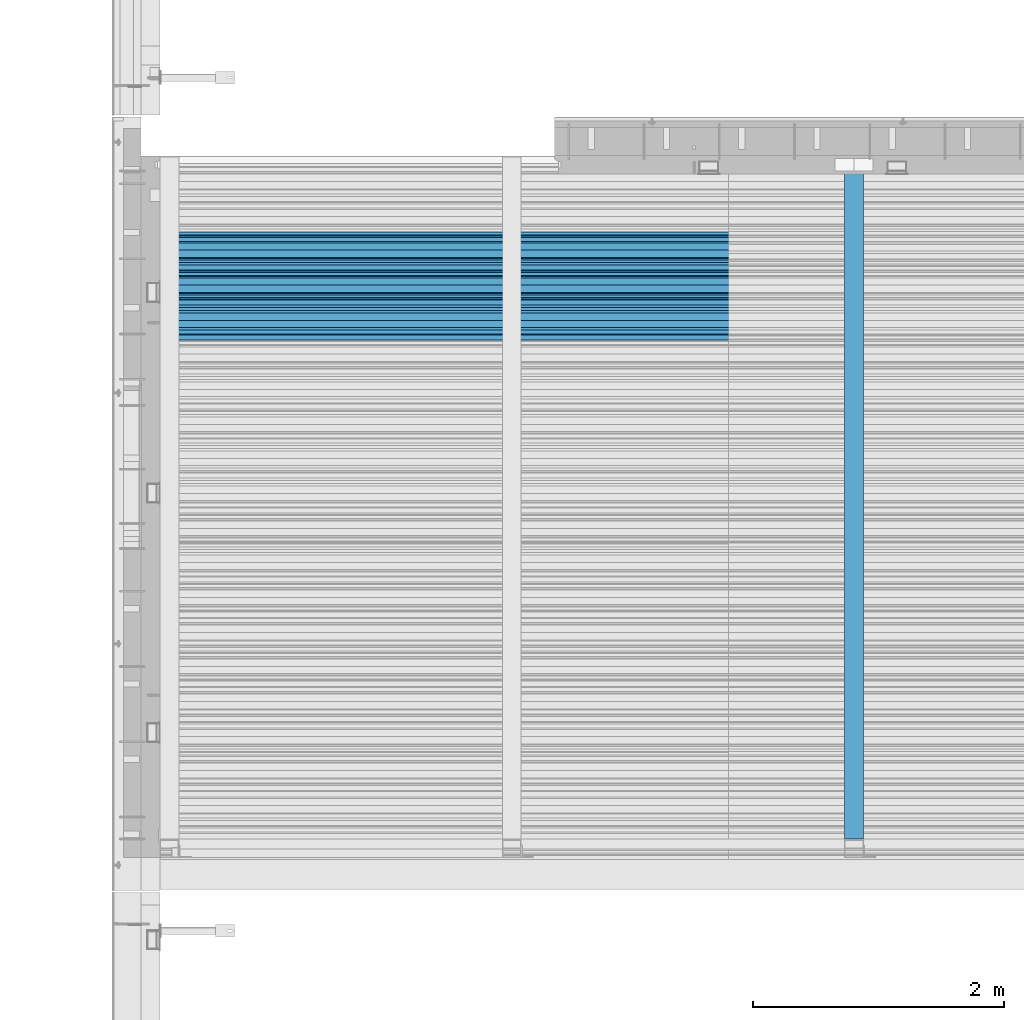
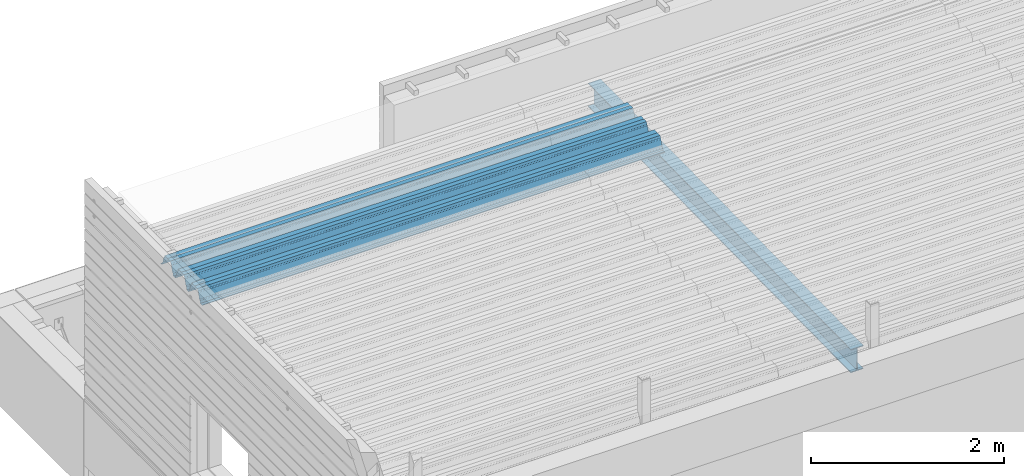
# One storey, part 29 of 153: 2 beams, 2 elements without a shape of their own.
"""IFC2X3 building model written with IfcOpenShell, lengths in millimetres."""

from ifc_helpers import new_model, si_unit, frame, origin_with_axes, place, context, subcontext, project, spatial, faceted_brep, material, type_object, element, aggregate, save


model = new_model("IFC2X3")

# Units and contexts
model_context = context("Model", 3, precision=1e-05, world=origin_with_axes())
body_context = subcontext(model_context, "Body", "Model", "MODEL_VIEW")
ifc_project = project(units=[si_unit("LENGTHUNIT", "METRE", prefix="MILLI"), si_unit("AREAUNIT", "SQUARE_METRE"), si_unit("VOLUMEUNIT", "CUBIC_METRE"), si_unit("MASSUNIT", "GRAM", prefix="KILO"), si_unit("TIMEUNIT", "SECOND"), si_unit("PLANEANGLEUNIT", "RADIAN"), si_unit("SOLIDANGLEUNIT", "STERADIAN"), si_unit("THERMODYNAMICTEMPERATUREUNIT", "DEGREE_CELSIUS"), si_unit("LUMINOUSINTENSITYUNIT", "LUMEN")], contexts=[model_context])

# Site, building, storey
site_placement = place(None, origin_with_axes())
site = spatial("IfcSite", under=ifc_project, at=site_placement, CompositionType="ELEMENT")
building_placement = place(site_placement, origin_with_axes())
building = spatial("IfcBuilding", under=site, at=building_placement, CompositionType="ELEMENT")
storey_placement = place(building_placement, origin_with_axes())
storey = spatial("IfcBuildingStorey", under=building, at=storey_placement, Name="8", CompositionType="ELEMENT", Elevation=0.0)

# Assembly, beam
assembly_1_placement = place(storey_placement, origin_with_axes())
assembly_1 = element("IfcElementAssembly", 1, at=assembly_1_placement, inside=storey, Name="Steel Assembly", AssemblyPlace="NOTDEFINED", PredefinedType="RIGID_FRAME")
ifc_material = material(Name="STEEL/S355J2")
beam_type_1 = type_object("IfcBeamType", Name="IPE300", PredefinedType="NOTDEFINED")
beam_1_placement = place(assembly_1_placement, frame((13535.0, 15128.0908589797, 105518.668698055), z_axis=(0.0, -0.0124990270013869, 0.999921884110963), x_axis=(0.0, 0.999921884110963, 0.0124990270013883)))
beam_1 = element("IfcBeam", 2, at=beam_1_placement, type_object=beam_type_1, material=ifc_material, ObjectType="IPE300", context=body_context, shape_type="Brep", body=[
    faceted_brep([(3.63797880709171e-12, 75.0, -149.999999999985), (0.0, 75.0, -139.300000189993), (5440.87494889885, 75.0, -139.300000189993), (5440.87494889886, 75.0, -150.0), (0.0, 3.5499999525, -139.300000189993), (5440.87494889885, 3.5499999525, -139.300000189993), (0.0, 3.5499999525, 139.300000190022), (5440.87494889885, 3.5499999525, 139.300000190022), (0.0, 75.0, 139.300000190022), (5440.87494889885, 75.0, 139.300000190022), (3.63797880709171e-12, 75.0, 150.0), (5440.87494889885, 75.0, 150.0), (3.63797880709171e-12, -75.0, 150.0), (5440.87494889885, -75.0, 150.0), (0.0, -75.0, 139.300000190022), (5440.87494889885, -75.0, 139.300000190022), (0.0, -3.5499999525, 139.300000190022), (5440.87494889885, -3.5499999525, 139.300000190022), (0.0, -3.5499999525, -139.300000189993), (5440.87494889885, -3.5499999525, -139.300000189993), (0.0, -75.0, -139.300000189993), (5440.87494889885, -75.0, -139.300000189993), (3.63797880709171e-12, -75.0, -149.999999999985), (5440.87494889886, -75.0, -150.0)], [[[0, 1, 2, 3]], [[1, 4, 5, 2]], [[4, 6, 7, 5]], [[6, 8, 9, 7]], [[8, 10, 11, 9]], [[10, 12, 13, 11]], [[12, 14, 15, 13]], [[14, 16, 17, 15]], [[16, 18, 19, 17]], [[18, 20, 21, 19]], [[20, 22, 23, 21]], [[22, 0, 3, 23]], [[5, 7, 9, 11, 13, 15, 17, 19, 21, 23, 3, 2]], [[22, 20, 18, 16, 14, 12, 10, 8, 6, 4, 1, 0]]]),
])
aggregate(assembly_1, [beam_1])

assembly_2_placement = place(storey_placement, origin_with_axes())
assembly_2 = element("IfcElementAssembly", 3, at=assembly_2_placement, inside=storey, Name="Steel Assembly", AssemblyPlace="NOTDEFINED", PredefinedType="RIGID_FRAME")
beam_type_2 = type_object("IfcBeamType", Name="W", PredefinedType="NOTDEFINED")
beam_2_placement = place(assembly_2_placement, frame((13534.9999999929, 19534.8848732893, 105801.771450403), z_axis=(0.0, -0.0124990270013869, 0.999921884110963), x_axis=(-1.0, 3.00000001838171e-08, 0.0)))
beam_2 = element("IfcBeam", 4, at=beam_2_placement, type_object=beam_type_2, material=ifc_material, ObjectType="W", context=body_context, shape_type="Brep", body=[
    faceted_brep([(0.0, -412.839996337891, -77.0100021362159), (0.0, -409.160003662109, -77.0100021362014), (5530.0, -409.160003662109, -77.0100021362014), (5530.0, -412.839996337891, -77.0100021362159), (0.0, -408.070007324222, -73.4800033569045), (5530.0, -408.070007324222, -73.4800033569045), (0.0, -400.339996337894, -48.0600013732619), (5530.0, -400.339996337894, -48.0600013732619), (0.0, -399.459991455082, -46.5600013732619), (5530.0, -399.459991455082, -46.5600013732619), (0.0, -390.329986572269, -36.5499992370314), (5530.0, -390.329986572269, -36.5499992370314), (0.0, -389.19000244141, -34.6300010680861), (5530.0, -389.19000244141, -34.6300010680861), (0.0, -367.820007324222, 35.3400001526024), (5530.0, -367.820007324222, 35.3400001526024), (0.0, -366.989990234379, 36.8499984741502), (5530.0, -366.989990234379, 36.8499984741502), (0.0, -357.809997558597, 46.8600006103807), (5530.0, -357.809997558597, 46.8600006103807), (0.0, -356.720001220707, 48.7700004577782), (5530.0, -356.720001220707, 48.7700004577782), (0.0, -349.309997558594, 73.1500015258935), (5530.0, -349.309997558594, 73.1500015258935), (0.0, -347.850006103516, 75.2300033569481), (5530.0, -347.850006103516, 75.2300033569481), (0.0, -345.470001220707, 76.010002136245), (5530.0, -345.470001220707, 76.010002136245), (0.0, -305.480010986332, 76.010002136245), (5530.0, -305.480010986332, 76.010002136245), (0.0, -304.279998779301, 75.8000030517578), (5530.0, -304.279998779301, 75.8000030517578), (0.0, -291.679992675785, 71.6999969482567), (5530.0, -291.679992675785, 71.6999969482567), (0.0, -290.179992675789, 71.2300033569481), (5530.0, -290.179992675789, 71.2300033569481), (0.0, -288.720001220707, 71.6999969482567), (5530.0, -288.720001220707, 71.6999969482567), (0.0, -276.119995117191, 75.8000030517869), (5530.0, -276.119995117191, 75.8000030517869), (0.0, -274.929992675785, 76.010002136245), (5530.0, -274.929992675785, 76.010002136245), (0.0, -234.94000244141, 76.010002136245), (5530.0, -234.94000244141, 76.010002136245), (0.0, -232.550003051758, 75.2300033569627), (5530.0, -232.550003051758, 75.2300033569627), (0.0, -231.100006103519, 73.1500015258935), (5530.0, -231.100006103519, 73.1500015258935), (0.0, -223.679992675785, 48.7700004577782), (5530.0, -223.679992675785, 48.7700004577782), (0.0, -222.589996337894, 46.8600006103661), (5530.0, -222.589996337894, 46.8600006103661), (0.0, -213.410003662113, 36.8499984741502), (5530.0, -213.410003662113, 36.8499984741502), (0.0, -212.529998779301, 35.3400001526024), (5530.0, -212.529998779301, 35.3400001526024), (0.0, -191.160003662109, -34.6300010681007), (5530.0, -191.160003662109, -34.6300010681007), (0.0, -190.070007324222, -36.5499992370605), (5530.0, -190.070007324222, -36.5499992370605), (0.0, -180.940002441406, -46.560001373291), (5530.0, -180.940002441406, -46.560001373291), (0.0, -180.059997558597, -48.0600013732619), (5530.0, -180.059997558597, -48.0600013732619), (0.0, -172.330001831055, -73.480003356919), (5530.0, -172.330001831055, -73.480003356919), (0.0, -171.240005493168, -77.0100021362159), (5530.0, -171.240005493168, -77.0100021362159), (0.0, -129.330001831062, -77.0100021362014), (5530.0, -129.330001831062, -77.0100021362014), (0.0, -128.300003051761, -73.480003356919), (5530.0, -128.300003051761, -73.480003356919), (0.0, -120.51999664307, -48.0600013732765), (5530.0, -120.51999664307, -48.0600013732765), (0.0, -119.629997253418, -46.5600013732765), (5530.0, -119.629997253418, -46.5600013732765), (0.0, -110.500000000004, -36.5499992370314), (5530.0, -110.500000000004, -36.5499992370314), (0.0, -109.419998168949, -34.6300010680861), (5530.0, -109.419998168949, -34.6300010680861), (0.0, -88.0500030517615, 35.3400001526024), (5530.0, -88.0500030517615, 35.3400001526024), (0.0, -87.160003662113, 36.8499984741356), (5530.0, -87.160003662113, 36.8499984741356), (0.0, -78.0400009155273, 46.8600006103807), (5530.0, -78.0400009155273, 46.8600006103807), (0.0, -76.8899993896557, 48.7700004577782), (5530.0, -76.8899993896557, 48.7700004577782), (0.0, -69.4800033569336, 73.1500015258935), (5530.0, -69.4800033569336, 73.1500015258935), (0.0, -68.0299987793042, 75.2300033569336), (5530.0, -68.0299987793042, 75.2300033569336), (0.0, -65.6399993896521, 76.010002136245), (5530.0, -65.6399993896521, 76.010002136245), (0.0, -25.6499996185375, 76.0100021362596), (5530.0, -25.6499996185375, 76.0100021362596), (0.0, -24.5100002288891, 75.8000030517724), (5530.0, -24.5100002288891, 75.8000030517724), (0.0, -11.8500003814697, 71.6999969482567), (5530.0, -11.8500003814697, 71.6999969482567), (0.0, -10.3999996185339, 71.2300033569481), (5530.0, -10.3999996185339, 71.2300033569481), (0.0, -8.89999961853391, 71.6999969482567), (5530.0, -8.89999961853391, 71.6999969482567), (0.0, 3.71000003814333, 75.8000030517724), (5530.0, 3.71000003814333, 75.8000030517724), (0.0, 4.90000009536379, 76.0100021362596), (5530.0, 4.90000009536379, 76.0100021362596), (0.0, 44.8899993896484, 76.010002136245), (5530.0, 44.8899993896484, 76.010002136245), (0.0, 47.2799987792932, 75.2300033569481), (5530.0, 47.2799987792932, 75.2300033569481), (0.0, 48.6800003051721, 73.1500015258935), (5530.0, 48.6800003051721, 73.1500015258935), (0.0, 56.1500015258753, 48.7700004577782), (5530.0, 56.1500015258753, 48.7700004577782), (0.0, 57.2400016784632, 46.8600006103807), (5530.0, 57.2400016784632, 46.8600006103807), (0.0, 66.3700027465784, 36.8499984741211), (5530.0, 66.3700027465784, 36.8499984741211), (0.0, 67.2499999999964, 35.3400001526024), (5530.0, 67.2499999999964, 35.3400001526024), (0.0, 88.6200027465748, -34.6300010681007), (5530.0, 88.6200027465748, -34.6300010681007), (0.0, 89.709999084469, -36.549999237046), (5530.0, 89.709999084469, -36.549999237046), (0.0, 98.8899993896412, -46.5600013732765), (5530.0, 98.8899993896412, -46.5600013732765), (0.0, 99.7699966430628, -48.0600013732765), (5530.0, 99.7699966430628, -48.0600013732765), (0.0, 107.499999999996, -73.4800033569336), (5530.0, 107.499999999996, -73.4800033569336), (0.0, 108.589996337887, -77.0100021362014), (5530.0, 108.589996337887, -77.0100021362014), (0.0, 112.269996643063, -77.0100021362159), (5530.0, 112.269996643063, -77.0100021362159), (0.0, 146.759994506836, -77.0100021362159), (5530.0, 146.759994506836, -77.0100021362159), (0.0, 150.440002441403, -77.0100021362159), (5530.0, 150.440002441403, -77.0100021362159), (0.0, 151.529998779297, -73.480003356919), (5530.0, 151.529998779297, -73.480003356919), (0.0, 159.30999755859, -48.0600013732765), (5530.0, 159.30999755859, -48.0600013732765), (0.0, 160.190002441406, -46.5600013732619), (5530.0, 160.190002441406, -46.5600013732619), (0.0, 169.320007324215, -36.549999237046), (5530.0, 169.320007324215, -36.549999237046), (0.0, 170.410003662106, -34.6300010680861), (5530.0, 170.410003662106, -34.6300010680861), (0.0, 191.779998779293, 35.3400001526024), (5530.0, 191.779998779293, 35.3400001526024), (0.0, 192.660003662109, 36.8499984741502), (5530.0, 192.660003662109, 36.8499984741502), (0.0, 201.789993286129, 46.8600006103661), (5530.0, 201.789993286129, 46.8600006103661), (0.0, 202.880004882809, 48.7700004577637), (5530.0, 202.880004882809, 48.7700004577637), (0.0, 210.350006103512, 73.150001525908), (5530.0, 210.350006103512, 73.150001525908), (0.0, 211.800003051754, 75.2300033569481), (5530.0, 211.800003051754, 75.2300033569481), (0.0, 214.190002441406, 76.010002136245), (5530.0, 214.190002441406, 76.010002136245), (0.0, 254.179992675778, 76.010002136245), (5530.0, 254.179992675778, 76.010002136245), (0.0, 255.320007324215, 75.8000030517869), (5530.0, 255.320007324215, 75.8000030517869), (0.0, 267.980010986324, 71.6999969482713), (5530.0, 267.980010986324, 71.6999969482713), (0.0, 269.429992675778, 71.2300033569481), (5530.0, 269.429992675778, 71.2300033569481), (0.0, 270.880004882809, 71.6999969482567), (5530.0, 270.880004882809, 71.6999969482567), (0.0, 283.540008544918, 75.8000030517869), (5530.0, 283.540008544918, 75.8000030517869), (0.0, 284.679992675778, 76.010002136245), (5530.0, 284.679992675778, 76.010002136245), (0.0, 324.670013427731, 76.010002136245), (5530.0, 324.670013427731, 76.010002136245), (0.0, 327.049987792969, 75.2300033569627), (5530.0, 327.049987792969, 75.2300033569627), (0.0, 328.510009765625, 73.1500015258789), (5530.0, 328.510009765625, 73.1500015258789), (0.0, 335.980010986324, 48.7700004577782), (5530.0, 335.980010986324, 48.7700004577782), (0.0, 337.05999755859, 46.8600006103661), (5530.0, 337.05999755859, 46.8600006103661), (0.0, 346.190002441399, 36.8499984741356), (5530.0, 346.190002441399, 36.8499984741356), (0.0, 347.079986572266, 35.3400001526024), (5530.0, 347.079986572266, 35.3400001526024), (0.0, 368.450012207028, -34.6300010680861), (5530.0, 368.450012207028, -34.6300010680861), (0.0, 369.529998779293, -36.5499992370314), (5530.0, 369.529998779293, -36.5499992370314), (0.0, 378.660003662106, -46.5600013732619), (5530.0, 378.660003662106, -46.5600013732619), (0.0, 379.540008544918, -48.0600013732619), (5530.0, 379.540008544918, -48.0600013732619), (0.0, 387.329986572262, -73.480003356919), (5530.0, 387.329986572262, -73.480003356919), (0.0, 388.410003662109, -77.0100021362159), (5530.0, 388.410003662109, -77.0100021362159), (0.0, 392.100006103512, -77.0100021362159), (5530.0, 392.100006103512, -77.0100021362159), (0.0, 426.589996337887, -77.0100021362159), (5530.0, 426.589996337887, -77.0100021362159), (0.0, 430.269989013668, -77.0100021362159), (5530.0, 430.269989013668, -77.0100021362159), (0.0, 431.359985351559, -73.4800033569045), (5530.0, 431.359985351559, -73.4800033569045), (0.0, 433.179992675778, -67.5699996948097), (5530.0, 433.179992675778, -67.5699996948097), (0.0, 432.220001220699, -67.2699966430373), (5530.0, 432.220001220699, -67.2699966430373), (0.0, 430.410003662106, -73.1800003051612), (5530.0, 430.410003662106, -73.1800003051612), (0.0, 429.529998779293, -76.0100021362159), (5530.0, 429.529998779293, -76.0100021362159), (0.0, 426.589996337891, -76.0100021362159), (5530.0, 426.589996337891, -76.0100021362159), (0.0, 392.100006103512, -76.0100021362159), (5530.0, 392.100006103512, -76.0100021362159), (0.0, 389.149993896481, -76.0100021362014), (5530.0, 389.149993896481, -76.0100021362014), (0.0, 388.279998779293, -73.1800003051467), (5530.0, 388.279998779293, -73.1800003051467), (0.0, 380.470001220699, -47.659999847383), (5530.0, 380.470001220699, -47.659999847383), (0.0, 379.470001220699, -45.9599990844436), (5530.0, 379.470001220699, -45.9599990844436), (0.0, 370.350006103512, -35.9599990844581), (5530.0, 370.350006103512, -35.9599990844581), (0.0, 369.369995117184, -34.2299995422218), (5530.0, 369.369995117184, -34.2299995422218), (0.0, 347.999999999996, 35.7500000000146), (5530.0, 347.999999999996, 35.7500000000146), (0.0, 346.999999999996, 37.4399986267235), (5530.0, 346.999999999996, 37.4399986267235), (0.0, 337.880004882809, 47.450000762954), (5530.0, 337.880004882809, 47.450000762954), (0.0, 336.899993896481, 49.1699981689453), (5530.0, 336.899993896481, 49.1699981689453), (0.0, 329.420013427731, 73.5999984741356), (5530.0, 329.420013427731, 73.5999984741356), (0.0, 327.679992675781, 76.0699996948533), (5530.0, 327.679992675781, 76.0699996948533), (0.0, 324.829986572262, 77.010002136245), (5530.0, 324.829986572262, 77.010002136245), (0.0, 284.589996337887, 77.010002136245), (5530.0, 284.589996337887, 77.010002136245), (0.0, 283.290008544922, 76.769996643081), (5530.0, 283.290008544922, 76.769996643081), (0.0, 270.570007324215, 72.6500015258935), (5530.0, 270.570007324215, 72.6500015258935), (0.0, 269.429992675781, 72.2799987793114), (5530.0, 269.429992675781, 72.2799987793114), (0.0, 268.279998779293, 72.650001525908), (5530.0, 268.279998779293, 72.650001525908), (0.0, 255.570007324219, 76.769996643081), (5530.0, 255.570007324219, 76.769996643081), (0.0, 254.270004272461, 77.0100021362596), (5530.0, 254.270004272461, 77.0100021362596), (0.0, 214.029998779293, 77.0100021362596), (5530.0, 214.029998779293, 77.0100021362596), (0.0, 211.179992675781, 76.0699996948388), (5530.0, 211.179992675781, 76.0699996948388), (0.0, 209.440002441403, 73.5999984741356), (5530.0, 209.440002441403, 73.5999984741356), (0.0, 201.960006713864, 49.1699981689599), (5530.0, 201.960006713864, 49.1699981689599), (0.0, 200.979995727532, 47.450000762954), (5530.0, 200.979995727532, 47.450000762954), (0.0, 191.850006103508, 37.4399986267235), (5530.0, 191.850006103508, 37.4399986267235), (0.0, 190.860000610352, 35.7500000000146), (5530.0, 190.860000610352, 35.7500000000146), (0.0, 169.49000549316, -34.2299995422218), (5530.0, 169.49000549316, -34.2299995422218), (0.0, 168.509994506832, -35.9599990844581), (5530.0, 168.509994506832, -35.9599990844581), (0.0, 159.380004882805, -45.9599990844436), (5530.0, 159.380004882805, -45.9599990844436), (0.0, 158.389999389645, -47.6599998473976), (5530.0, 158.389999389645, -47.6599998473976), (0.0, 150.580001831051, -73.1800003051612), (5530.0, 150.580001831051, -73.1800003051612), (0.0, 149.710006713864, -76.0100021362159), (5530.0, 149.710006713864, -76.0100021362159), (0.0, 146.759994506836, -76.0100021362159), (5530.0, 146.759994506836, -76.0100021362159), (0.0, 112.269996643063, -76.0100021362159), (5530.0, 112.269996643063, -76.0100021362159), (0.0, 109.319999694821, -76.0100021362159), (5530.0, 109.319999694821, -76.0100021362159), (0.0, 108.449996948239, -73.1900024413917), (5530.0, 108.449996948239, -73.1900024413917), (0.0, 100.690002441406, -47.659999847383), (5530.0, 100.690002441406, -47.659999847383), (0.0, 99.6999969482386, -45.9599990844581), (5530.0, 99.6999969482386, -45.9599990844581), (0.0, 90.5199966430664, -35.9599990844581), (5530.0, 90.5199966430664, -35.9599990844581), (0.0, 89.5400009155273, -34.2299995422218), (5530.0, 89.5400009155273, -34.2299995422218), (0.0, 68.1699981689417, 35.7500000000146), (5530.0, 68.1699981689417, 35.7500000000146), (0.0, 67.1699981689417, 37.4399986267235), (5530.0, 67.1699981689417, 37.4399986267235), (0.0, 58.0499992370569, 47.4500007629686), (5530.0, 58.0499992370569, 47.4500007629686), (0.0, 57.0699996948206, 49.1699981689599), (5530.0, 57.0699996948206, 49.1699981689599), (0.0, 49.5900001525843, 73.5899963379052), (5530.0, 49.5900001525843, 73.5899963379052), (0.0, 47.9099998474085, 76.0699996948388), (5530.0, 47.9099998474085, 76.0699996948388), (0.0, 45.0499992370569, 77.010002136245), (5530.0, 45.0499992370569, 77.010002136245), (0.0, 4.82000017165774, 77.010002136245), (5530.0, 4.82000017165774, 77.010002136245), (0.0, 3.47000002860659, 76.7699966430955), (5530.0, 3.47000002860659, 76.7699966430955), (0.0, -9.19999980926514, 72.6500015258935), (5530.0, -9.19999980926514, 72.6500015258935), (0.0, -10.3900003433264, 72.2799987792969), (5530.0, -10.3900003433264, 72.2799987792969), (0.0, -11.5399999618567, 72.6500015258935), (5530.0, -11.5399999618567, 72.6500015258935), (0.0, -24.2600002288855, 76.769996643081), (5530.0, -24.2600002288855, 76.769996643081), (0.0, -25.559999465946, 77.0100021362596), (5530.0, -25.559999465946, 77.0100021362596), (0.0, -65.8000030517615, 77.0100021362596), (5530.0, -65.8000030517615, 77.0100021362596), (0.0, -68.6500015258862, 76.0699996948533), (5530.0, -68.6500015258862, 76.0699996948533), (0.0, -70.3899993896521, 73.5999984741356), (5530.0, -70.3899993896521, 73.5999984741356), (0.0, -77.8199996948242, 49.1800003051903), (5530.0, -77.8199996948242, 49.1800003051903), (0.0, -78.8399963378943, 47.450000762954), (5530.0, -78.8399963378943, 47.450000762954), (0.0, -87.9700012207031, 37.4399986267235), (5530.0, -87.9700012207031, 37.4399986267235), (0.0, -88.9700012207068, 35.7500000000146), (5530.0, -88.9700012207068, 35.7500000000146), (0.0, -110.339996337894, -34.2299995422218), (5530.0, -110.339996337894, -34.2299995422218), (0.0, -111.319999694828, -35.9599990844581), (5530.0, -111.319999694828, -35.9599990844581), (0.0, -120.440002441406, -45.9599990844436), (5530.0, -120.440002441406, -45.9599990844436), (0.0, -121.44000244141, -47.6599998473976), (5530.0, -121.44000244141, -47.6599998473976), (0.0, -129.250000000004, -73.1900024413771), (5530.0, -129.250000000004, -73.1900024413771), (0.0, -130.080001831062, -76.0100021362159), (5530.0, -130.080001831062, -76.0100021362159), (0.0, -170.5, -76.0100021362014), (5530.0, -170.5, -76.0100021362014), (0.0, -171.380004882816, -73.1900024413917), (5530.0, -171.380004882816, -73.1900024413917), (0.0, -179.139999389652, -47.6599998473976), (5530.0, -179.139999389652, -47.6599998473976), (0.0, -180.130004882816, -45.9599990844581), (5530.0, -180.130004882816, -45.9599990844581), (0.0, -189.259994506836, -35.9599990844581), (5530.0, -189.259994506836, -35.9599990844581), (0.0, -190.240005493168, -34.2299995422218), (5530.0, -190.240005493168, -34.2299995422218), (0.0, -211.610000610355, 35.7500000000146), (5530.0, -211.610000610355, 35.7500000000146), (0.0, -212.600006103519, 37.4399986267381), (5530.0, -212.600006103519, 37.4399986267381), (0.0, -221.779998779301, 47.450000762954), (5530.0, -221.779998779301, 47.450000762954), (0.0, -222.75999450684, 49.1699981689599), (5530.0, -222.75999450684, 49.1699981689599), (0.0, -230.190002441406, 73.5999984741356), (5530.0, -230.190002441406, 73.5999984741356), (0.0, -231.919998168945, 76.0699996948388), (5530.0, -231.919998168945, 76.0699996948388), (0.0, -234.779998779301, 77.010002136245), (5530.0, -234.779998779301, 77.010002136245), (0.0, -275.010009765629, 77.010002136245), (5530.0, -275.010009765629, 77.010002136245), (0.0, -276.359985351563, 76.769996643081), (5530.0, -276.359985351563, 76.769996643081), (0.0, -289.029998779297, 72.6500015258789), (5530.0, -289.029998779297, 72.6500015258789), (0.0, -290.179992675785, 72.2799987793114), (5530.0, -290.179992675785, 72.2799987793114), (0.0, -291.380004882816, 72.650001525908), (5530.0, -291.380004882816, 72.650001525908), (0.0, -304.040008544926, 76.769996643081), (5530.0, -304.040008544926, 76.769996643081), (0.0, -305.390014648441, 77.010002136245), (5530.0, -305.390014648441, 77.010002136245), (0.0, -345.63000488282, 77.0100021362596), (5530.0, -345.63000488282, 77.0100021362596), (0.0, -348.480010986332, 76.0699996948388), (5530.0, -348.480010986332, 76.0699996948388), (0.0, -350.220001220707, 73.5999984741356), (5530.0, -350.220001220707, 73.5999984741356), (0.0, -357.649993896492, 49.1699981689599), (5530.0, -357.649993896492, 49.1699981689599), (0.0, -358.63000488282, 47.450000762954), (5530.0, -358.63000488282, 47.450000762954), (0.0, -367.809997558594, 37.4300003051903), (5530.0, -367.809997558594, 37.4300003051903), (0.0, -368.750000000004, 35.7299995422654), (5530.0, -368.750000000004, 35.7299995422654), (0.0, -390.109985351566, -34.2200012207031), (5530.0, -390.109985351566, -34.2200012207031), (0.0, -391.140014648441, -35.9500007629249), (5530.0, -391.140014648441, -35.9500007629249), (0.0, -400.269989013676, -45.9599990844436), (5530.0, -400.269989013676, -45.9599990844436), (0.0, -401.269989013672, -47.6599998473976), (5530.0, -401.269989013672, -47.6599998473976), (0.0, -409.029998779297, -73.1900024413917), (5530.0, -409.029998779297, -73.1900024413917), (0.0, -409.899993896488, -76.0100021362159), (5530.0, -409.899993896488, -76.0100021362159), (0.0, -412.839996337891, -76.0100021362159), (5530.0, -412.839996337891, -76.0100021362159), (0.0, -433.179992675785, -76.0100021362159), (5530.0, -433.179992675785, -76.0100021362159), (0.0, -433.179992675785, -77.0100021362159), (5530.0, -433.179992675785, -77.0100021362159)], [[[0, 1, 2, 3]], [[1, 4, 5, 2]], [[4, 6, 7, 5]], [[6, 8, 9, 7]], [[8, 10, 11, 9]], [[10, 12, 13, 11]], [[12, 14, 15, 13]], [[14, 16, 17, 15]], [[16, 18, 19, 17]], [[18, 20, 21, 19]], [[20, 22, 23, 21]], [[22, 24, 25, 23]], [[24, 26, 27, 25]], [[26, 28, 29, 27]], [[28, 30, 31, 29]], [[30, 32, 33, 31]], [[32, 34, 35, 33]], [[34, 36, 37, 35]], [[36, 38, 39, 37]], [[38, 40, 41, 39]], [[40, 42, 43, 41]], [[42, 44, 45, 43]], [[44, 46, 47, 45]], [[46, 48, 49, 47]], [[48, 50, 51, 49]], [[50, 52, 53, 51]], [[52, 54, 55, 53]], [[54, 56, 57, 55]], [[56, 58, 59, 57]], [[58, 60, 61, 59]], [[60, 62, 63, 61]], [[62, 64, 65, 63]], [[64, 66, 67, 65]], [[66, 68, 69, 67]], [[68, 70, 71, 69]], [[70, 72, 73, 71]], [[72, 74, 75, 73]], [[74, 76, 77, 75]], [[76, 78, 79, 77]], [[78, 80, 81, 79]], [[80, 82, 83, 81]], [[82, 84, 85, 83]], [[84, 86, 87, 85]], [[86, 88, 89, 87]], [[88, 90, 91, 89]], [[90, 92, 93, 91]], [[92, 94, 95, 93]], [[94, 96, 97, 95]], [[96, 98, 99, 97]], [[98, 100, 101, 99]], [[100, 102, 103, 101]], [[102, 104, 105, 103]], [[104, 106, 107, 105]], [[106, 108, 109, 107]], [[108, 110, 111, 109]], [[110, 112, 113, 111]], [[112, 114, 115, 113]], [[114, 116, 117, 115]], [[116, 118, 119, 117]], [[118, 120, 121, 119]], [[120, 122, 123, 121]], [[122, 124, 125, 123]], [[124, 126, 127, 125]], [[126, 128, 129, 127]], [[128, 130, 131, 129]], [[130, 132, 133, 131]], [[132, 134, 135, 133]], [[134, 136, 137, 135]], [[136, 138, 139, 137]], [[138, 140, 141, 139]], [[140, 142, 143, 141]], [[142, 144, 145, 143]], [[144, 146, 147, 145]], [[146, 148, 149, 147]], [[148, 150, 151, 149]], [[150, 152, 153, 151]], [[152, 154, 155, 153]], [[154, 156, 157, 155]], [[156, 158, 159, 157]], [[158, 160, 161, 159]], [[160, 162, 163, 161]], [[162, 164, 165, 163]], [[164, 166, 167, 165]], [[166, 168, 169, 167]], [[168, 170, 171, 169]], [[170, 172, 173, 171]], [[172, 174, 175, 173]], [[174, 176, 177, 175]], [[176, 178, 179, 177]], [[178, 180, 181, 179]], [[180, 182, 183, 181]], [[182, 184, 185, 183]], [[184, 186, 187, 185]], [[186, 188, 189, 187]], [[188, 190, 191, 189]], [[190, 192, 193, 191]], [[192, 194, 195, 193]], [[194, 196, 197, 195]], [[196, 198, 199, 197]], [[198, 200, 201, 199]], [[200, 202, 203, 201]], [[202, 204, 205, 203]], [[204, 206, 207, 205]], [[206, 208, 209, 207]], [[208, 210, 211, 209]], [[210, 212, 213, 211]], [[212, 214, 215, 213]], [[214, 216, 217, 215]], [[216, 218, 219, 217]], [[218, 220, 221, 219]], [[220, 222, 223, 221]], [[222, 224, 225, 223]], [[224, 226, 227, 225]], [[226, 228, 229, 227]], [[228, 230, 231, 229]], [[230, 232, 233, 231]], [[232, 234, 235, 233]], [[234, 236, 237, 235]], [[236, 238, 239, 237]], [[238, 240, 241, 239]], [[240, 242, 243, 241]], [[242, 244, 245, 243]], [[244, 246, 247, 245]], [[246, 248, 249, 247]], [[248, 250, 251, 249]], [[250, 252, 253, 251]], [[252, 254, 255, 253]], [[254, 256, 257, 255]], [[256, 258, 259, 257]], [[258, 260, 261, 259]], [[260, 262, 263, 261]], [[262, 264, 265, 263]], [[264, 266, 267, 265]], [[266, 268, 269, 267]], [[268, 270, 271, 269]], [[270, 272, 273, 271]], [[272, 274, 275, 273]], [[274, 276, 277, 275]], [[276, 278, 279, 277]], [[278, 280, 281, 279]], [[280, 282, 283, 281]], [[282, 284, 285, 283]], [[284, 286, 287, 285]], [[286, 288, 289, 287]], [[288, 290, 291, 289]], [[290, 292, 293, 291]], [[292, 294, 295, 293]], [[294, 296, 297, 295]], [[296, 298, 299, 297]], [[298, 300, 301, 299]], [[300, 302, 303, 301]], [[302, 304, 305, 303]], [[304, 306, 307, 305]], [[306, 308, 309, 307]], [[308, 310, 311, 309]], [[310, 312, 313, 311]], [[312, 314, 315, 313]], [[314, 316, 317, 315]], [[316, 318, 319, 317]], [[318, 320, 321, 319]], [[320, 322, 323, 321]], [[322, 324, 325, 323]], [[324, 326, 327, 325]], [[326, 328, 329, 327]], [[328, 330, 331, 329]], [[330, 332, 333, 331]], [[332, 334, 335, 333]], [[334, 336, 337, 335]], [[336, 338, 339, 337]], [[338, 340, 341, 339]], [[340, 342, 343, 341]], [[342, 344, 345, 343]], [[344, 346, 347, 345]], [[346, 348, 349, 347]], [[348, 350, 351, 349]], [[350, 352, 353, 351]], [[352, 354, 355, 353]], [[354, 356, 357, 355]], [[356, 358, 359, 357]], [[358, 360, 361, 359]], [[360, 362, 363, 361]], [[362, 364, 365, 363]], [[364, 366, 367, 365]], [[366, 368, 369, 367]], [[368, 370, 371, 369]], [[370, 372, 373, 371]], [[372, 374, 375, 373]], [[374, 376, 377, 375]], [[376, 378, 379, 377]], [[378, 380, 381, 379]], [[380, 382, 383, 381]], [[382, 384, 385, 383]], [[384, 386, 387, 385]], [[386, 388, 389, 387]], [[388, 390, 391, 389]], [[390, 392, 393, 391]], [[392, 394, 395, 393]], [[394, 396, 397, 395]], [[396, 398, 399, 397]], [[398, 400, 401, 399]], [[400, 402, 403, 401]], [[402, 404, 405, 403]], [[404, 406, 407, 405]], [[406, 408, 409, 407]], [[408, 410, 411, 409]], [[410, 412, 413, 411]], [[412, 414, 415, 413]], [[414, 416, 417, 415]], [[416, 418, 419, 417]], [[418, 420, 421, 419]], [[420, 422, 423, 421]], [[422, 424, 425, 423]], [[424, 426, 427, 425]], [[426, 428, 429, 427]], [[428, 430, 431, 429]], [[430, 0, 3, 431]], [[5, 7, 9, 11, 13, 15, 17, 19, 21, 23, 25, 27, 29, 31, 33, 35, 37, 39, 41, 43, 45, 47, 49, 51, 53, 55, 57, 59, 61, 63, 65, 67, 69, 71, 73, 75, 77, 79, 81, 83, 85, 87, 89, 91, 93, 95, 97, 99, 101, 103, 105, 107, 109, 111, 113, 115, 117, 119, 121, 123, 125, 127, 129, 131, 133, 135, 137, 139, 141, 143, 145, 147, 149, 151, 153, 155, 157, 159, 161, 163, 165, 167, 169, 171, 173, 175, 177, 179, 181, 183, 185, 187, 189, 191, 193, 195, 197, 199, 201, 203, 205, 207, 209, 211, 213, 215, 217, 219, 221, 223, 225, 227, 229, 231, 233, 235, 237, 239, 241, 243, 245, 247, 249, 251, 253, 255, 257, 259, 261, 263, 265, 267, 269, 271, 273, 275, 277, 279, 281, 283, 285, 287, 289, 291, 293, 295, 297, 299, 301, 303, 305, 307, 309, 311, 313, 315, 317, 319, 321, 323, 325, 327, 329, 331, 333, 335, 337, 339, 341, 343, 345, 347, 349, 351, 353, 355, 357, 359, 361, 363, 365, 367, 369, 371, 373, 375, 377, 379, 381, 383, 385, 387, 389, 391, 393, 395, 397, 399, 401, 403, 405, 407, 409, 411, 413, 415, 417, 419, 421, 423, 425, 427, 429, 431, 3, 2]], [[430, 428, 426, 424, 422, 420, 418, 416, 414, 412, 410, 408, 406, 404, 402, 400, 398, 396, 394, 392, 390, 388, 386, 384, 382, 380, 378, 376, 374, 372, 370, 368, 366, 364, 362, 360, 358, 356, 354, 352, 350, 348, 346, 344, 342, 340, 338, 336, 334, 332, 330, 328, 326, 324, 322, 320, 318, 316, 314, 312, 310, 308, 306, 304, 302, 300, 298, 296, 294, 292, 290, 288, 286, 284, 282, 280, 278, 276, 274, 272, 270, 268, 266, 264, 262, 260, 258, 256, 254, 252, 250, 248, 246, 244, 242, 240, 238, 236, 234, 232, 230, 228, 226, 224, 222, 220, 218, 216, 214, 212, 210, 208, 206, 204, 202, 200, 198, 196, 194, 192, 190, 188, 186, 184, 182, 180, 178, 176, 174, 172, 170, 168, 166, 164, 162, 160, 158, 156, 154, 152, 150, 148, 146, 144, 142, 140, 138, 136, 134, 132, 130, 128, 126, 124, 122, 120, 118, 116, 114, 112, 110, 108, 106, 104, 102, 100, 98, 96, 94, 92, 90, 88, 86, 84, 82, 80, 78, 76, 74, 72, 70, 68, 66, 64, 62, 60, 58, 56, 54, 52, 50, 48, 46, 44, 42, 40, 38, 36, 34, 32, 30, 28, 26, 24, 22, 20, 18, 16, 14, 12, 10, 8, 6, 4, 1, 0]]]),
])
aggregate(assembly_2, [beam_2])

save(model, "model.ifc")
